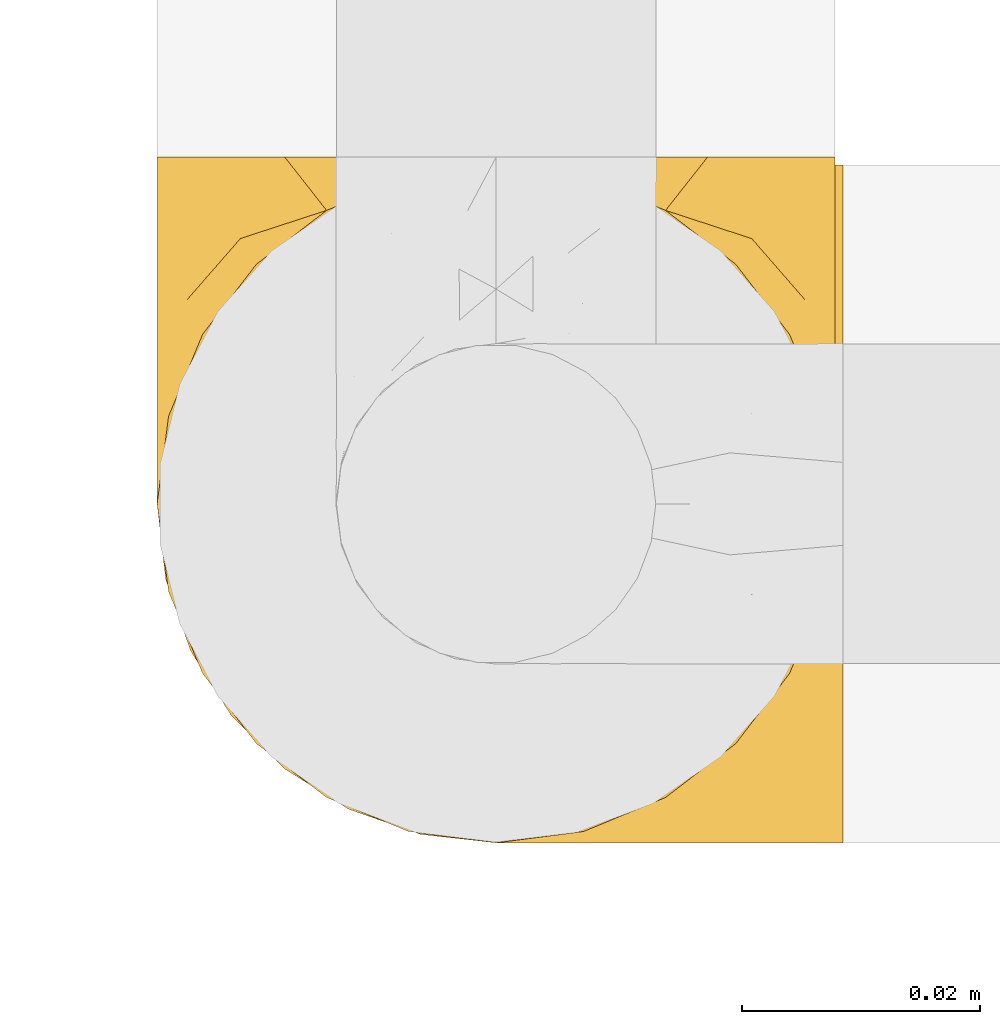
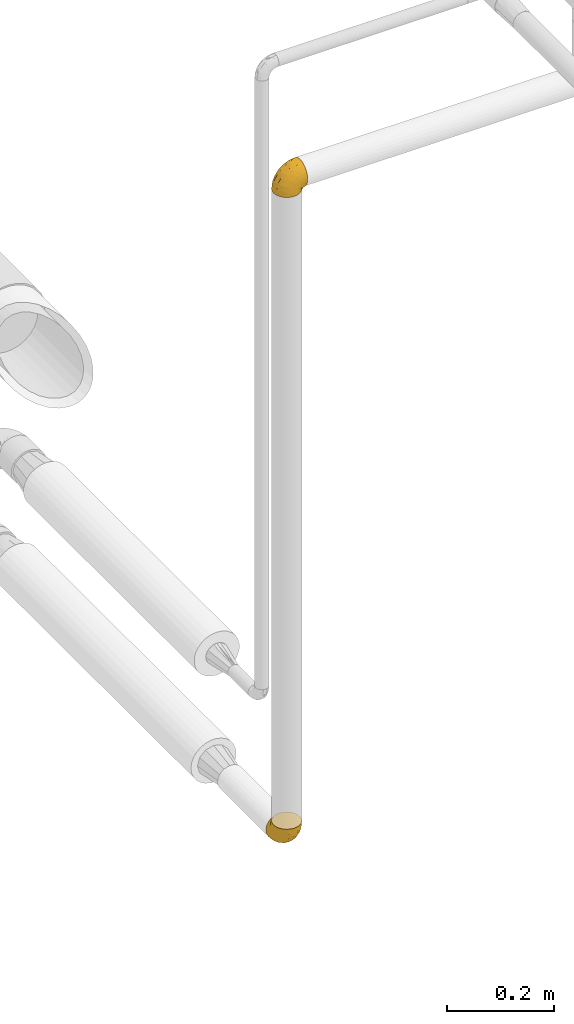
# One storey, part 517 of 827: 2 coverings.
"""IFC2X3 building model written with IfcOpenShell, lengths in millimetres."""

from ifc_helpers import new_model, entity, si_unit, converted_unit, derived_unit, direction, frame, origin, place, context, subcontext, project, spatial, faceted_brep, element, save


model = new_model("IFC2X3")

# Units and contexts
model_context = context("Model", 3, precision=0.01, world=origin(), true_north=direction((6.12303176911189e-17, 1.0)))
body_context = subcontext(model_context, "Body", "Model", "MODEL_VIEW")
ifc_project = project(units=[si_unit("LENGTHUNIT", "METRE", prefix="MILLI"), si_unit("AREAUNIT", "SQUARE_METRE"), si_unit("VOLUMEUNIT", "CUBIC_METRE"), converted_unit("PLANEANGLEUNIT", "DEGREE", entity("IfcRatioMeasure", 0.0174532925199433), si_unit("PLANEANGLEUNIT", "RADIAN"), dimensions=[0, 0, 0, 0, 0, 0, 0]), si_unit("MASSUNIT", "GRAM", prefix="KILO"), derived_unit("MASSDENSITYUNIT", [(si_unit("MASSUNIT", "GRAM", prefix="KILO"), 1), (si_unit("LENGTHUNIT", "METRE"), -3)]), derived_unit("MOMENTOFINERTIAUNIT", [(si_unit("LENGTHUNIT", "METRE"), 4)]), si_unit("TIMEUNIT", "SECOND"), si_unit("FREQUENCYUNIT", "HERTZ"), si_unit("THERMODYNAMICTEMPERATUREUNIT", "DEGREE_CELSIUS"), derived_unit("THERMALTRANSMITTANCEUNIT", [(si_unit("MASSUNIT", "GRAM", prefix="KILO"), 1), (si_unit("THERMODYNAMICTEMPERATUREUNIT", "KELVIN"), -1), (si_unit("TIMEUNIT", "SECOND"), -3)]), derived_unit("VOLUMETRICFLOWRATEUNIT", [(si_unit("LENGTHUNIT", "METRE"), 3), (si_unit("TIMEUNIT", "SECOND"), -1)]), derived_unit("MASSFLOWRATEUNIT", [(si_unit("MASSUNIT", "GRAM", prefix="KILO"), 1), (si_unit("TIMEUNIT", "SECOND"), -1)]), derived_unit("ROTATIONALFREQUENCYUNIT", [(si_unit("TIMEUNIT", "SECOND"), -1)]), si_unit("ELECTRICCURRENTUNIT", "AMPERE"), si_unit("ELECTRICVOLTAGEUNIT", "VOLT"), si_unit("POWERUNIT", "WATT"), si_unit("FORCEUNIT", "NEWTON", prefix="KILO"), si_unit("ILLUMINANCEUNIT", "LUX"), si_unit("LUMINOUSFLUXUNIT", "LUMEN"), si_unit("LUMINOUSINTENSITYUNIT", "CANDELA"), derived_unit("USERDEFINED", [(si_unit("MASSUNIT", "GRAM", prefix="KILO"), -1), (si_unit("LENGTHUNIT", "METRE"), -2), (si_unit("TIMEUNIT", "SECOND"), 3), (si_unit("LUMINOUSFLUXUNIT", "LUMEN"), 1)]), derived_unit("LINEARVELOCITYUNIT", [(si_unit("LENGTHUNIT", "METRE"), 1), (si_unit("TIMEUNIT", "SECOND"), -1)]), si_unit("PRESSUREUNIT", "PASCAL"), derived_unit("USERDEFINED", [(si_unit("LENGTHUNIT", "METRE"), -2), (si_unit("MASSUNIT", "GRAM", prefix="KILO"), 1), (si_unit("TIMEUNIT", "SECOND"), -2)]), derived_unit("LINEARFORCEUNIT", [(si_unit("MASSUNIT", "GRAM", prefix="KILO"), 1), (si_unit("LENGTHUNIT", "METRE"), 1), (si_unit("TIMEUNIT", "SECOND"), -2), (si_unit("LENGTHUNIT", "METRE"), -1)]), derived_unit("PLANARFORCEUNIT", [(si_unit("MASSUNIT", "GRAM", prefix="KILO"), 1), (si_unit("LENGTHUNIT", "METRE"), 1), (si_unit("TIMEUNIT", "SECOND"), -2), (si_unit("LENGTHUNIT", "METRE"), -2)])], contexts=[model_context])

# Site, building, storey
site_placement = place(None, origin())
site = spatial("IfcSite", under=ifc_project, at=site_placement, CompositionType="ELEMENT")
building_placement = place(site_placement, origin())
building = spatial("IfcBuilding", under=site, at=building_placement, CompositionType="ELEMENT")
storey_placement = place(building_placement, frame((0.0, 0.0, 28200.0)))
storey = spatial("IfcBuildingStorey", under=building, at=storey_placement, Name="08", CompositionType="ELEMENT", Elevation=28200.0)

# Coverings
covering_1_placement = place(storey_placement, frame((22834.32, 10792.34, 2773.62)))
element("IfcCovering", 1, at=covering_1_placement, inside=storey, Name=":ADSK_", ObjectType=":ADSK_", PredefinedType="INSULATION", context=body_context, shape_type="Brep", body=[
    faceted_brep([(23.71, 2.31, 1.6), (17.7, 4.41, 1.6), (12.3, 7.81, 1.6), (7.8, 12.31, 1.6), (4.41, 17.71, 1.6), (2.31, 23.72, 1.6), (1.6, 30.05, 1.6), (2.31, 36.38, 1.6), (4.41, 42.39, 1.6), (7.81, 47.79, 1.6), (12.31, 52.29, 1.6), (17.71, 55.68, 1.6), (23.72, 57.78, 1.6), (30.05, 58.5, 1.6), (36.38, 57.78, 1.6), (42.39, 55.68, 1.6), (47.79, 52.28, 1.6), (52.29, 47.78, 1.6), (55.68, 42.39, 1.6), (57.78, 36.37, 1.6), (58.14, 33.21, 1.6), (58.5, 30.05, 1.6), (58.14, 26.88, 1.6), (57.78, 23.71, 1.6), (55.68, 17.7, 1.6), (52.28, 12.3, 1.6), (47.78, 7.8, 1.6), (42.39, 4.41, 1.6), (36.37, 2.31, 1.6), (30.05, 1.6, 1.6), (59.15, 50.16, 10.58), (59.15, 54.68, 16.47), (59.15, 56.1, 19.9), (59.15, 57.53, 23.33), (59.15, 57.89, 26.11), (59.15, 58.19, 28.4), (59.15, 58.5, 30.7), (59.15, 57.53, 38.06), (59.15, 54.68, 44.92), (59.15, 50.16, 50.81), (59.15, 44.27, 55.33), (59.15, 37.41, 58.18), (59.15, 30.05, 59.15), (59.15, 22.68, 58.18), (59.15, 15.82, 55.33), (59.15, 9.93, 50.81), (59.15, 5.41, 44.92), (59.15, 2.56, 38.06), (59.15, 1.6, 30.7), (59.15, 2.2, 26.11), (59.15, 2.56, 23.33), (59.15, 3.99, 19.9), (59.15, 5.41, 16.47), (59.15, 9.93, 10.58), (59.15, 15.82, 6.06), (59.15, 22.68, 3.21), (59.15, 26.36, 2.73), (59.15, 30.05, 2.25), (59.15, 33.73, 2.73), (59.15, 37.41, 3.21), (59.15, 44.27, 6.06), (33.94, 1.6, 16.15), (33.03, 2.88, 28.57), (26.2, 2.26, 13.99), (48.13, 30.05, 56.95), (45.89, 20.32, 55.84), (33.99, 10.06, 44.05), (39.8, 5.6, 40.73), (46.18, 8.91, 47.96), (37.58, 15.18, 50.4), (49.1, 13.81, 53.09), (10.29, 11.43, 14.82), (32.37, 22.62, 51.42), (24.24, 17.24, 43.46), (29.16, 5.92, 34.03), (21.57, 4.95, 21.46), (46.29, 2.4, 35.01), (23.74, 10.49, 36.56), (7.29, 23.82, 24.92), (9.39, 17.33, 23.97), (12.89, 23.33, 34.47), (50.48, 4.49, 42.29), (44.6, 1.6, 26.8), (48.47, 1.6, 27.84), (52.35, 1.6, 28.88), (4.36, 21.7, 14.55), (5.98, 30.05, 23.62), (6.24, 15.92, 11.37), (3.79, 30.05, 12.61), (19.4, 4.15, 11.22), (14.49, 7.02, 11.8), (39.27, 1.6, 21.47), (31.87, 1.6, 8.39), (16.28, 9.26, 24.35), (12.28, 12.93, 23.71), (37.12, 30.05, 54.76), (20.68, 23.45, 43.36), (27.79, 30.05, 48.53), (18.45, 30.05, 42.29), (16.44, 15.39, 33.8), (12.21, 30.05, 32.95), (52.36, 2.48, 22.6), (46.53, 4.12, 13.56), (51.27, 8.58, 8.43), (45.85, 2.25, 20.39), (38.35, 2.39, 10.02), (58.69, 30.05, 2.05), (51.28, 51.5, 8.42), (38.36, 57.7, 10.02), (52.36, 57.61, 22.6), (52.35, 58.5, 28.88), (46.54, 55.97, 13.55), (55.75, 58.5, 29.79), (39.27, 58.5, 21.47), (45.86, 57.84, 20.39), (33.94, 58.5, 16.15), (44.6, 58.5, 26.8), (31.87, 58.5, 8.39), (46.19, 51.18, 47.96), (19.42, 55.94, 11.22), (26.2, 57.83, 13.99), (46.29, 57.69, 35.01), (32.37, 37.47, 51.42), (45.89, 39.77, 55.84), (37.58, 44.91, 50.4), (24.24, 42.85, 43.46), (39.81, 54.49, 40.73), (34.0, 50.03, 44.05), (10.3, 48.67, 14.83), (33.03, 57.22, 28.56), (50.49, 55.6, 42.29), (49.11, 46.28, 53.09), (27.48, 54.21, 32.33), (21.57, 55.14, 21.46), (14.5, 53.08, 11.8), (16.29, 50.84, 24.34), (7.46, 36.88, 24.95), (12.9, 36.77, 34.48), (6.25, 44.18, 11.37), (9.4, 42.77, 23.99), (16.45, 44.71, 33.8), (12.29, 47.17, 23.72), (4.36, 38.39, 14.56), (20.7, 36.64, 43.37), (23.75, 49.6, 36.57)], [[[0, 1, 2, 3, 4, 5, 6, 7, 8, 9, 10, 11, 12, 13, 14, 15, 16, 17, 18, 19, 20, 21, 22, 23, 24, 25, 26, 27, 28, 29]], [[30, 31, 32, 33, 34, 35, 36, 37, 38, 39, 40, 41, 42, 43, 44, 45, 46, 47, 48, 49, 50, 51, 52, 53, 54, 55, 56, 57, 58, 59, 60]], [[61, 62, 63]], [[43, 64, 65]], [[66, 67, 68]], [[65, 69, 70]], [[71, 3, 2]], [[69, 72, 73]], [[29, 63, 0]], [[65, 44, 43]], [[74, 75, 62]], [[44, 70, 45]], [[76, 48, 47]], [[46, 45, 68]], [[66, 73, 77]], [[78, 79, 80]], [[47, 46, 81]], [[76, 82, 83, 84, 48]], [[85, 78, 86]], [[69, 65, 72]], [[79, 85, 87]], [[87, 85, 4]], [[87, 4, 3]], [[5, 85, 88]], [[76, 62, 82]], [[89, 63, 75]], [[75, 90, 89]], [[62, 61, 91, 82]], [[68, 67, 81]], [[63, 29, 92, 61]], [[71, 93, 94]], [[63, 62, 75]], [[66, 74, 67]], [[71, 90, 93]], [[2, 90, 71]], [[90, 2, 1]], [[72, 65, 95]], [[85, 5, 4]], [[74, 62, 67]], [[88, 6, 5]], [[70, 68, 45]], [[66, 77, 74]], [[96, 97, 98]], [[79, 99, 80]], [[97, 96, 72]], [[99, 77, 73]], [[81, 76, 47]], [[62, 76, 67]], [[3, 71, 87]], [[79, 87, 71]], [[89, 90, 1]], [[93, 90, 75]], [[74, 93, 75]], [[93, 77, 99]], [[1, 0, 89]], [[63, 89, 0]], [[68, 69, 66]], [[73, 66, 69]], [[65, 70, 44]], [[68, 70, 69]], [[80, 96, 98]], [[99, 79, 94]], [[96, 99, 73]], [[80, 98, 100]], [[72, 95, 97]], [[68, 81, 46]], [[76, 81, 67]], [[85, 86, 88]], [[64, 43, 42]], [[64, 95, 65]], [[74, 77, 93]], [[99, 94, 93]], [[79, 71, 94]], [[99, 96, 80]], [[72, 96, 73]], [[79, 78, 85]], [[78, 100, 86]], [[100, 78, 80]], [[50, 101, 52, 51]], [[102, 103, 52]], [[82, 91, 104]], [[101, 104, 102]], [[105, 91, 61]], [[91, 105, 104]], [[54, 53, 103]], [[22, 57, 56]], [[55, 23, 56]], [[104, 101, 82]], [[56, 23, 22]], [[55, 54, 24]], [[102, 26, 103]], [[102, 27, 26]], [[49, 48, 84, 83]], [[103, 26, 25]], [[105, 28, 27]], [[104, 105, 102]], [[105, 92, 28]], [[92, 29, 28]], [[22, 21, 106]], [[57, 22, 106]], [[52, 103, 53]], [[24, 54, 25]], [[103, 25, 54]], [[102, 52, 101]], [[55, 24, 23]], [[27, 102, 105]], [[92, 105, 61]], [[83, 82, 101]], [[101, 50, 49]], [[83, 101, 49]], [[107, 60, 17]], [[108, 15, 14]], [[106, 20, 57]], [[109, 110, 34]], [[16, 111, 107]], [[18, 60, 59]], [[112, 36, 35, 34, 110]], [[107, 31, 30]], [[113, 114, 108]], [[30, 60, 107]], [[109, 34, 33]], [[108, 115, 113]], [[31, 111, 109]], [[21, 20, 106]], [[31, 109, 33, 32]], [[19, 58, 20]], [[19, 59, 58]], [[107, 17, 16]], [[20, 58, 57]], [[17, 60, 18]], [[113, 116, 114]], [[16, 15, 111]], [[31, 107, 111]], [[114, 111, 108]], [[115, 108, 117]], [[108, 14, 117]], [[116, 110, 109]], [[111, 15, 108]], [[14, 13, 117]], [[18, 59, 19]], [[109, 111, 114]], [[116, 109, 114]], [[39, 38, 118]], [[119, 120, 12]], [[121, 36, 112, 110, 116]], [[122, 123, 124]], [[125, 122, 124]], [[126, 127, 118]], [[64, 42, 41]], [[10, 9, 128]], [[64, 41, 123]], [[121, 129, 126]], [[118, 38, 130]], [[131, 40, 39]], [[38, 37, 130]], [[40, 131, 123]], [[132, 129, 133]], [[133, 134, 135]], [[115, 120, 129]], [[120, 133, 129]], [[13, 12, 120]], [[136, 100, 137]], [[138, 9, 8]], [[139, 136, 137]], [[123, 95, 64]], [[128, 134, 10]], [[140, 135, 141]], [[142, 138, 8]], [[7, 142, 8]], [[121, 130, 37]], [[7, 88, 142]], [[120, 115, 117, 13]], [[126, 129, 132]], [[139, 128, 138]], [[36, 121, 37]], [[95, 123, 122]], [[129, 116, 113, 115]], [[134, 119, 11]], [[10, 134, 11]], [[40, 123, 41]], [[126, 132, 127]], [[131, 118, 124]], [[124, 127, 125]], [[143, 97, 122]], [[144, 140, 125]], [[137, 143, 140]], [[129, 121, 116]], [[130, 121, 126]], [[139, 138, 142]], [[128, 9, 138]], [[135, 134, 128]], [[119, 134, 133]], [[141, 135, 128]], [[132, 135, 144]], [[120, 119, 133]], [[12, 11, 119]], [[125, 127, 144]], [[124, 118, 127]], [[118, 131, 39]], [[123, 131, 124]], [[135, 140, 144]], [[137, 140, 139]], [[139, 142, 136]], [[143, 137, 98]], [[122, 125, 143]], [[97, 95, 122]], [[118, 130, 126]], [[88, 7, 6]], [[88, 86, 142]], [[135, 132, 133]], [[132, 144, 127]], [[128, 139, 141]], [[140, 141, 139]], [[142, 86, 136]], [[143, 98, 97]], [[100, 136, 86]], [[100, 98, 137]], [[140, 143, 125]]]),
])
covering_2_placement = place(storey_placement, frame((22834.32, 10792.34, 1270.52)))
element("IfcCovering", 2, at=covering_2_placement, inside=storey, Name=":ADSK_", ObjectType=":ADSK_", PredefinedType="INSULATION", context=body_context, shape_type="Brep", body=[
    faceted_brep([(57.78, 59.15, 23.71), (55.68, 59.15, 17.7), (52.28, 59.15, 12.3), (47.78, 59.15, 7.8), (42.39, 59.15, 4.41), (36.37, 59.15, 2.31), (30.05, 59.15, 1.6), (23.71, 59.15, 2.31), (17.7, 59.15, 4.41), (12.3, 59.15, 7.81), (7.8, 59.15, 12.31), (4.41, 59.15, 17.71), (2.31, 59.15, 23.72), (1.6, 59.15, 30.05), (2.31, 59.15, 36.38), (4.41, 59.15, 42.39), (7.81, 59.15, 47.79), (12.31, 59.15, 52.29), (17.71, 59.15, 55.68), (23.72, 59.15, 57.78), (26.88, 59.15, 58.14), (30.05, 59.15, 58.5), (33.21, 59.15, 58.14), (36.38, 59.15, 57.78), (42.39, 59.15, 55.68), (47.79, 59.15, 52.28), (52.29, 59.15, 47.78), (55.68, 59.15, 42.39), (57.78, 59.15, 36.37), (58.5, 59.15, 30.05), (9.93, 50.16, 59.15), (5.41, 44.27, 59.15), (3.99, 40.84, 59.15), (2.56, 37.41, 59.15), (2.2, 34.63, 59.15), (1.9, 32.34, 59.15), (1.6, 30.05, 59.15), (2.56, 22.68, 59.15), (5.41, 15.82, 59.15), (9.93, 9.93, 59.15), (15.82, 5.41, 59.15), (22.68, 2.56, 59.15), (30.05, 1.6, 59.15), (37.41, 2.56, 59.15), (44.27, 5.41, 59.15), (50.16, 9.93, 59.15), (54.68, 15.82, 59.15), (57.53, 22.68, 59.15), (58.5, 30.05, 59.15), (57.89, 34.63, 59.15), (57.53, 37.41, 59.15), (56.1, 40.84, 59.15), (54.68, 44.27, 59.15), (50.16, 50.16, 59.15), (44.27, 54.68, 59.15), (37.41, 57.53, 59.15), (33.73, 58.01, 59.15), (30.05, 58.5, 59.15), (26.36, 58.01, 59.15), (22.68, 57.53, 59.15), (15.82, 54.68, 59.15), (58.5, 44.6, 33.94), (57.21, 32.17, 33.03), (57.83, 46.75, 26.2), (30.05, 3.79, 48.13), (39.77, 4.9, 45.89), (50.03, 16.69, 33.99), (54.49, 20.01, 39.8), (51.18, 12.78, 46.18), (44.91, 10.34, 37.58), (46.28, 7.65, 49.1), (48.66, 45.92, 10.29), (37.47, 9.32, 32.37), (42.85, 17.28, 24.24), (54.17, 26.71, 29.16), (55.14, 39.28, 21.57), (57.69, 25.73, 46.29), (49.6, 24.18, 23.74), (36.27, 35.82, 7.29), (42.76, 36.77, 9.39), (36.76, 26.28, 12.89), (55.6, 18.46, 50.48), (58.5, 33.94, 44.6), (58.5, 32.9, 48.47), (58.5, 31.87, 52.35), (38.39, 46.19, 4.36), (30.05, 37.12, 5.98), (44.17, 49.37, 6.24), (30.05, 48.13, 3.79), (55.94, 49.52, 19.4), (53.08, 48.94, 14.49), (58.5, 39.27, 39.27), (58.5, 52.35, 31.87), (50.83, 36.39, 16.28), (47.16, 37.03, 12.28), (30.05, 5.98, 37.12), (36.64, 17.38, 20.68), (30.05, 12.21, 27.79), (30.05, 18.45, 18.45), (44.7, 26.94, 16.44), (30.05, 27.79, 12.21), (57.61, 38.14, 52.36), (55.97, 47.18, 46.53), (51.51, 52.31, 51.27), (57.84, 40.35, 45.85), (57.7, 50.72, 38.35), (30.05, 58.69, 58.69), (8.59, 52.32, 51.28), (2.39, 50.72, 38.36), (2.48, 38.14, 52.36), (1.6, 31.87, 52.35), (4.12, 47.19, 46.54), (1.6, 30.96, 55.75), (1.6, 39.27, 39.27), (2.25, 40.35, 45.86), (1.6, 44.6, 33.94), (1.6, 33.94, 44.6), (1.6, 52.35, 31.87), (8.91, 12.78, 46.19), (4.15, 49.52, 19.42), (2.26, 46.75, 26.2), (2.4, 25.73, 46.29), (22.62, 9.32, 32.37), (20.32, 4.9, 45.89), (15.18, 10.34, 37.58), (17.24, 17.28, 24.24), (5.6, 20.01, 39.81), (10.06, 16.69, 34.0), (11.42, 45.91, 10.3), (2.87, 32.18, 33.03), (4.49, 18.46, 50.49), (13.81, 7.65, 49.11), (5.89, 28.41, 27.48), (4.95, 39.28, 21.57), (7.01, 48.94, 14.5), (9.25, 36.4, 16.29), (23.21, 35.79, 7.46), (23.32, 26.26, 12.9), (15.91, 49.37, 6.25), (17.33, 36.75, 9.4), (15.38, 26.94, 16.45), (12.92, 37.02, 12.29), (21.7, 46.18, 4.36), (23.45, 17.37, 20.7), (10.49, 24.17, 23.75)], [[[0, 1, 2, 3, 4, 5, 6, 7, 8, 9, 10, 11, 12, 13, 14, 15, 16, 17, 18, 19, 20, 21, 22, 23, 24, 25, 26, 27, 28, 29]], [[30, 31, 32, 33, 34, 35, 36, 37, 38, 39, 40, 41, 42, 43, 44, 45, 46, 47, 48, 49, 50, 51, 52, 53, 54, 55, 56, 57, 58, 59, 60]], [[61, 62, 63]], [[43, 64, 65]], [[66, 67, 68]], [[65, 69, 70]], [[71, 3, 2]], [[69, 72, 73]], [[29, 63, 0]], [[65, 44, 43]], [[74, 75, 62]], [[44, 70, 45]], [[76, 48, 47]], [[46, 45, 68]], [[66, 73, 77]], [[78, 79, 80]], [[47, 46, 81]], [[76, 82, 83, 84, 48]], [[85, 78, 86]], [[69, 65, 72]], [[79, 85, 87]], [[87, 85, 4]], [[87, 4, 3]], [[5, 85, 88]], [[76, 62, 82]], [[89, 63, 75]], [[75, 90, 89]], [[62, 61, 91, 82]], [[68, 67, 81]], [[63, 29, 92, 61]], [[71, 93, 94]], [[63, 62, 75]], [[66, 74, 67]], [[71, 90, 93]], [[2, 90, 71]], [[90, 2, 1]], [[72, 65, 95]], [[85, 5, 4]], [[74, 62, 67]], [[88, 6, 5]], [[70, 68, 45]], [[66, 77, 74]], [[96, 97, 98]], [[79, 99, 80]], [[97, 96, 72]], [[99, 77, 73]], [[81, 76, 47]], [[62, 76, 67]], [[3, 71, 87]], [[79, 87, 71]], [[89, 90, 1]], [[93, 90, 75]], [[74, 93, 75]], [[93, 77, 99]], [[1, 0, 89]], [[63, 89, 0]], [[68, 69, 66]], [[73, 66, 69]], [[65, 70, 44]], [[68, 70, 69]], [[80, 96, 98]], [[99, 79, 94]], [[96, 99, 73]], [[80, 98, 100]], [[72, 95, 97]], [[68, 81, 46]], [[76, 81, 67]], [[85, 86, 88]], [[64, 43, 42]], [[64, 95, 65]], [[74, 77, 93]], [[99, 94, 93]], [[79, 71, 94]], [[99, 96, 80]], [[72, 96, 73]], [[79, 78, 85]], [[78, 100, 86]], [[100, 78, 80]], [[50, 101, 52, 51]], [[102, 103, 52]], [[82, 91, 104]], [[101, 104, 102]], [[105, 91, 61]], [[91, 105, 104]], [[54, 53, 103]], [[22, 57, 56]], [[55, 23, 56]], [[104, 101, 82]], [[56, 23, 22]], [[55, 54, 24]], [[102, 26, 103]], [[102, 27, 26]], [[49, 48, 84, 83]], [[103, 26, 25]], [[105, 28, 27]], [[104, 105, 102]], [[105, 92, 28]], [[92, 29, 28]], [[22, 21, 106]], [[57, 22, 106]], [[52, 103, 53]], [[24, 54, 25]], [[103, 25, 54]], [[102, 52, 101]], [[55, 24, 23]], [[27, 102, 105]], [[92, 105, 61]], [[83, 82, 101]], [[101, 50, 49]], [[83, 101, 49]], [[107, 60, 17]], [[108, 15, 14]], [[106, 20, 57]], [[109, 110, 34]], [[16, 111, 107]], [[18, 60, 59]], [[35, 34, 110, 112, 36]], [[107, 31, 30]], [[113, 114, 108]], [[30, 60, 107]], [[109, 34, 33]], [[108, 115, 113]], [[31, 111, 109]], [[21, 20, 106]], [[31, 109, 33, 32]], [[19, 58, 20]], [[19, 59, 58]], [[107, 17, 16]], [[20, 58, 57]], [[17, 60, 18]], [[113, 116, 114]], [[16, 15, 111]], [[31, 107, 111]], [[114, 111, 108]], [[115, 108, 117]], [[108, 14, 117]], [[116, 110, 109]], [[111, 15, 108]], [[14, 13, 117]], [[18, 59, 19]], [[109, 111, 114]], [[116, 109, 114]], [[39, 38, 118]], [[119, 120, 12]], [[121, 36, 112, 110, 116]], [[122, 123, 124]], [[125, 122, 124]], [[126, 127, 118]], [[64, 42, 41]], [[10, 9, 128]], [[64, 41, 123]], [[121, 129, 126]], [[118, 38, 130]], [[131, 40, 39]], [[38, 37, 130]], [[40, 131, 123]], [[132, 129, 133]], [[133, 134, 135]], [[115, 120, 129]], [[120, 133, 129]], [[13, 12, 120]], [[136, 100, 137]], [[138, 9, 8]], [[139, 136, 137]], [[123, 95, 64]], [[128, 134, 10]], [[140, 135, 141]], [[142, 138, 8]], [[7, 142, 8]], [[121, 130, 37]], [[7, 88, 142]], [[120, 115, 117, 13]], [[126, 129, 132]], [[139, 128, 138]], [[36, 121, 37]], [[95, 123, 122]], [[129, 116, 113, 115]], [[134, 119, 11]], [[10, 134, 11]], [[40, 123, 41]], [[126, 132, 127]], [[131, 118, 124]], [[124, 127, 125]], [[143, 97, 122]], [[144, 140, 125]], [[137, 143, 140]], [[129, 121, 116]], [[130, 121, 126]], [[139, 138, 142]], [[128, 9, 138]], [[135, 134, 128]], [[119, 134, 133]], [[141, 135, 128]], [[132, 135, 144]], [[120, 119, 133]], [[12, 11, 119]], [[125, 127, 144]], [[124, 118, 127]], [[118, 131, 39]], [[123, 131, 124]], [[135, 140, 144]], [[137, 140, 139]], [[139, 142, 136]], [[143, 137, 98]], [[122, 125, 143]], [[97, 95, 122]], [[118, 130, 126]], [[88, 7, 6]], [[88, 86, 142]], [[135, 132, 133]], [[132, 144, 127]], [[128, 139, 141]], [[140, 141, 139]], [[142, 86, 136]], [[143, 98, 97]], [[100, 136, 86]], [[100, 98, 137]], [[140, 143, 125]]]),
])

save(model, "model.ifc")
